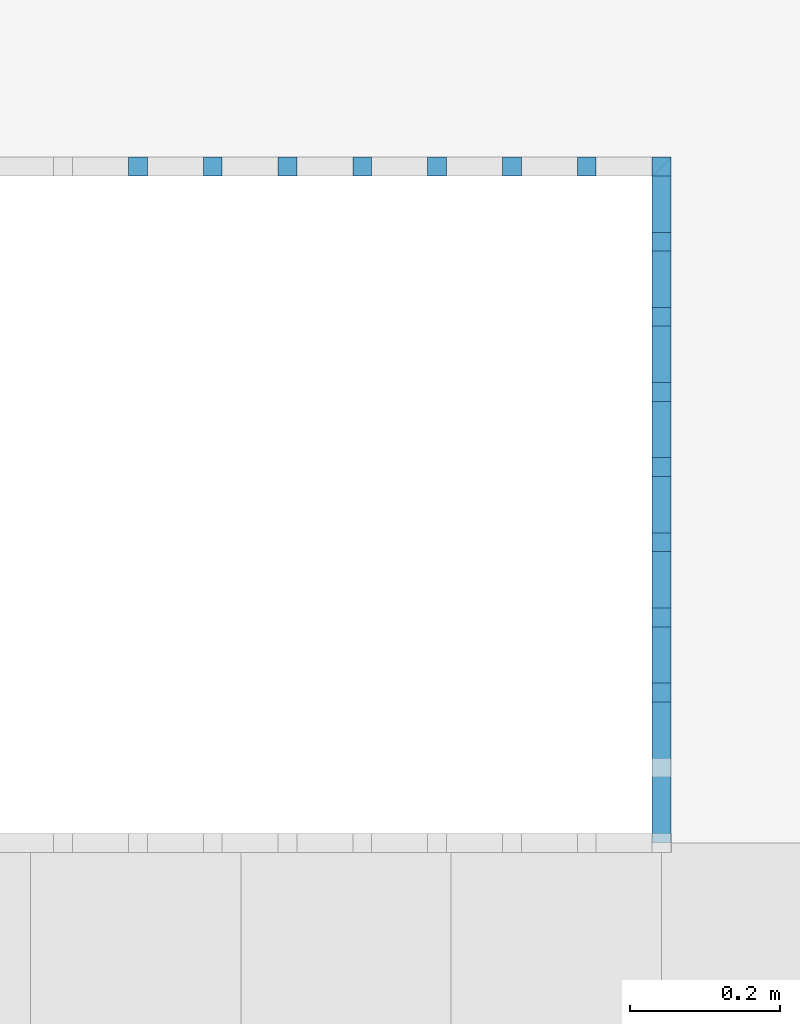
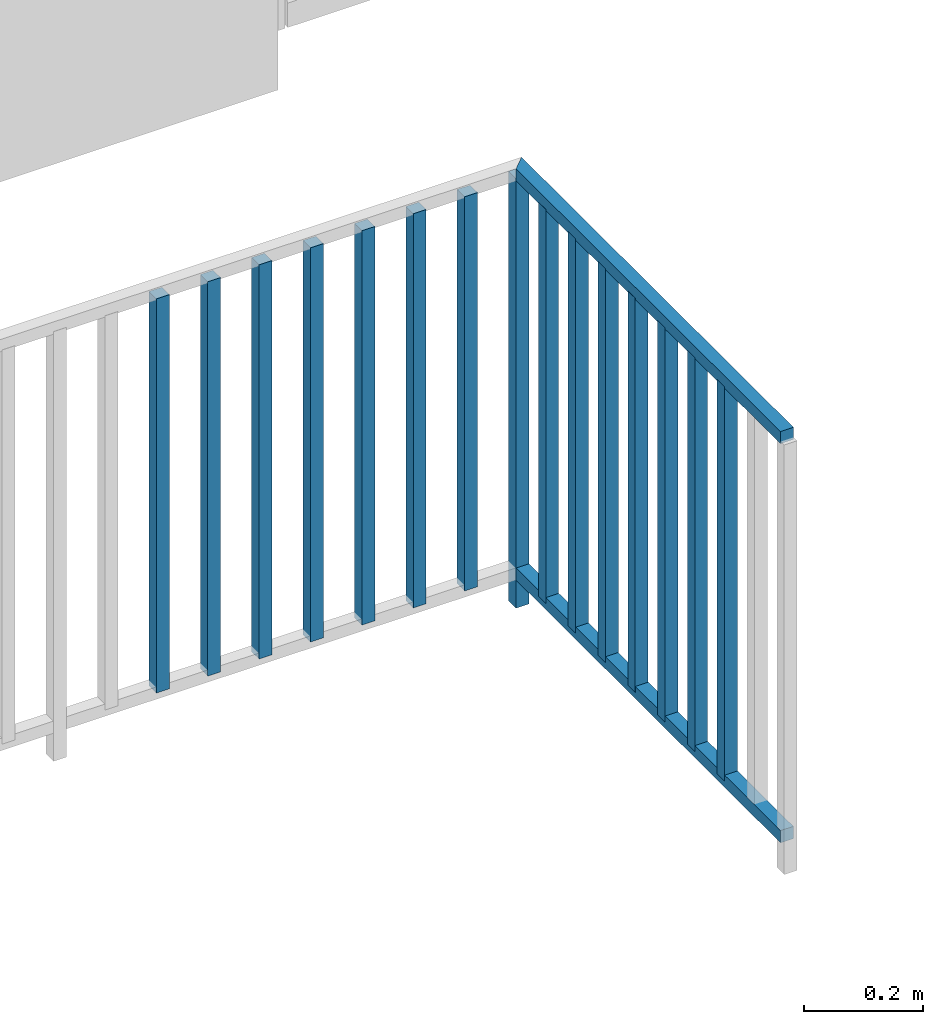
# One storey, part 35 of 48: 17 building element parts, 1 element without a shape of its own.
"""IFC4 building model written with IfcOpenShell, lengths in metres."""

from ifc_helpers import new_model, entity, si_unit, converted_unit, derived_unit, direction, frame, origin_with_axes, place, context, subcontext, project, spatial, polygons, material, type_object, element, aggregate, save


model = new_model("IFC4")

# Units and contexts
model_context = context("Model", 3, precision=1e-05, world=origin_with_axes(), true_north=direction((0.0, 1.0)))
body_context = subcontext(model_context, "Body", "Model", "MODEL_VIEW")
ifc_project = project(units=[si_unit("LENGTHUNIT", "METRE"), si_unit("AREAUNIT", "SQUARE_METRE"), si_unit("VOLUMEUNIT", "CUBIC_METRE"), converted_unit("PLANEANGLEUNIT", "DEGREE", entity("IfcPlaneAngleMeasure", 0.0174532925199), si_unit("PLANEANGLEUNIT", "RADIAN"), dimensions=[0, 0, 0, 0, 0, 0, 0]), converted_unit("TIMEUNIT", "Year", entity("IfcTimeMeasure", 31556926.0), si_unit("TIMEUNIT", "SECOND"), dimensions=[0, 0, 1, 0, 0, 0, 0]), si_unit("MASSUNIT", "GRAM", prefix="KILO"), si_unit("THERMODYNAMICTEMPERATUREUNIT", "DEGREE_CELSIUS"), si_unit("LUMINOUSINTENSITYUNIT", "LUMEN"), si_unit("ENERGYUNIT", "JOULE", prefix="MEGA"), derived_unit("THERMALCONDUCTANCEUNIT", [(si_unit("POWERUNIT", "WATT"), 1), (si_unit("LENGTHUNIT", "METRE"), -1), (si_unit("THERMODYNAMICTEMPERATUREUNIT", "KELVIN"), -1)]), derived_unit("SPECIFICHEATCAPACITYUNIT", [(si_unit("ENERGYUNIT", "JOULE"), 1), (si_unit("MASSUNIT", "GRAM", prefix="KILO"), -1), (si_unit("THERMODYNAMICTEMPERATUREUNIT", "KELVIN"), -1)]), derived_unit("MASSDENSITYUNIT", [(si_unit("MASSUNIT", "GRAM", prefix="KILO"), 1), (si_unit("VOLUMEUNIT", "CUBIC_METRE"), -1)])], contexts=[model_context])

# Site, building, storey, space
site_placement = place(None, origin_with_axes())
site = spatial("IfcSite", under=ifc_project, at=site_placement, CompositionType="ELEMENT")
building_placement = place(site_placement, origin_with_axes())
building = spatial("IfcBuilding", under=site, at=building_placement, CompositionType="ELEMENT")
storey_placement = place(building_placement, frame((0.0, 0.0, 3.4), z_axis=(0.0, 0.0, 1.0), x_axis=(1.0, 0.0, 0.0)))
storey = spatial("IfcBuildingStorey", under=building, at=storey_placement, Name="1. Geschoss", CompositionType="ELEMENT", Elevation=3.4)
space_placement = place(storey_placement, frame((-3.4421993804, -2.52881223104, 0.0), z_axis=(0.0, 0.0, 1.0), x_axis=(1.0, 0.0, 0.0)))
space = spatial("IfcSpace", under=storey, at=space_placement, CompositionType="ELEMENT", PredefinedType="INTERNAL")

# Railing, building element parts
railing_type = type_object("IfcRailingType", PredefinedType="NOTDEFINED")
railing_placement = place(space_placement, frame((0.0, 1.5, 0.0), z_axis=(0.0, 0.0, 1.0), x_axis=(1.0, 0.0, 0.0)))
railing = element("IfcRailing", 1, at=railing_placement, inside=space, type_object=railing_type, PredefinedType="NOTDEFINED")
ifc_material = material()
building_element_part_1_placement = place(railing_placement, origin_with_axes())
building_element_part_1 = element("IfcBuildingElementPart", 2, at=building_element_part_1_placement, material=ifc_material, PredefinedType="NOTDEFINED", context=body_context, shape_type="Tessellation", body=[
    polygons([(4.4925, 0.8875, 0.0), (4.4925, 0.9125, 0.0), (4.4925, 0.9125, 0.88), (4.4925, 0.8875, 0.88), (4.4675, 0.8875, 0.0), (4.4675, 0.9125, 0.0), (4.4675, 0.9125, 0.88), (4.4675, 0.8875, 0.88)], [[[1, 2, 3, 4]], [[1, 5, 6, 2]], [[2, 6, 7, 3]], [[4, 3, 7, 8]], [[5, 1, 4, 8]], [[6, 5, 8, 7]]], closed=True),
])
building_element_part_2_placement = place(railing_placement, origin_with_axes())
building_element_part_2 = element("IfcBuildingElementPart", 3, at=building_element_part_2_placement, material=ifc_material, PredefinedType="NOTDEFINED", context=body_context, shape_type="Tessellation", body=[
    polygons([(3.79561111111, 0.8875, 0.07), (3.79561111111, 0.9125, 0.07), (3.79561111111, 0.9125, 0.8775), (3.79561111111, 0.8875, 0.8775), (3.77061111111, 0.8875, 0.07), (3.77061111111, 0.9125, 0.07), (3.77061111111, 0.9125, 0.8775), (3.77061111111, 0.8875, 0.8775)], [[[1, 2, 3, 4]], [[1, 5, 6, 2]], [[2, 6, 7, 3]], [[4, 3, 7, 8]], [[5, 1, 4, 8]], [[6, 5, 8, 7]]], closed=True),
])
building_element_part_3_placement = place(railing_placement, origin_with_axes())
building_element_part_3 = element("IfcBuildingElementPart", 4, at=building_element_part_3_placement, material=ifc_material, PredefinedType="NOTDEFINED", context=body_context, shape_type="Tessellation", body=[
    polygons([(3.89516666667, 0.8875, 0.07), (3.89516666667, 0.9125, 0.07), (3.89516666667, 0.9125, 0.8775), (3.89516666667, 0.8875, 0.8775), (3.87016666667, 0.8875, 0.07), (3.87016666667, 0.9125, 0.07), (3.87016666667, 0.9125, 0.8775), (3.87016666667, 0.8875, 0.8775)], [[[1, 2, 3, 4]], [[1, 5, 6, 2]], [[2, 6, 7, 3]], [[4, 3, 7, 8]], [[5, 1, 4, 8]], [[6, 5, 8, 7]]], closed=True),
])
building_element_part_4_placement = place(railing_placement, origin_with_axes())
building_element_part_4 = element("IfcBuildingElementPart", 5, at=building_element_part_4_placement, material=ifc_material, PredefinedType="NOTDEFINED", context=body_context, shape_type="Tessellation", body=[
    polygons([(3.99472222222, 0.8875, 0.07), (3.99472222222, 0.9125, 0.07), (3.99472222222, 0.9125, 0.8775), (3.99472222222, 0.8875, 0.8775), (3.96972222222, 0.8875, 0.07), (3.96972222222, 0.9125, 0.07), (3.96972222222, 0.9125, 0.8775), (3.96972222222, 0.8875, 0.8775)], [[[1, 2, 3, 4]], [[1, 5, 6, 2]], [[2, 6, 7, 3]], [[4, 3, 7, 8]], [[5, 1, 4, 8]], [[6, 5, 8, 7]]], closed=True),
])
building_element_part_5_placement = place(railing_placement, origin_with_axes())
building_element_part_5 = element("IfcBuildingElementPart", 6, at=building_element_part_5_placement, material=ifc_material, PredefinedType="NOTDEFINED", context=body_context, shape_type="Tessellation", body=[
    polygons([(4.09427777778, 0.8875, 0.07), (4.09427777778, 0.9125, 0.07), (4.09427777778, 0.9125, 0.8775), (4.09427777778, 0.8875, 0.8775), (4.06927777778, 0.8875, 0.07), (4.06927777778, 0.9125, 0.07), (4.06927777778, 0.9125, 0.8775), (4.06927777778, 0.8875, 0.8775)], [[[1, 2, 3, 4]], [[1, 5, 6, 2]], [[2, 6, 7, 3]], [[4, 3, 7, 8]], [[5, 1, 4, 8]], [[6, 5, 8, 7]]], closed=True),
])
building_element_part_6_placement = place(railing_placement, origin_with_axes())
building_element_part_6 = element("IfcBuildingElementPart", 7, at=building_element_part_6_placement, material=ifc_material, PredefinedType="NOTDEFINED", context=body_context, shape_type="Tessellation", body=[
    polygons([(4.19383333333, 0.8875, 0.07), (4.19383333333, 0.9125, 0.07), (4.19383333333, 0.9125, 0.8775), (4.19383333333, 0.8875, 0.8775), (4.16883333333, 0.8875, 0.07), (4.16883333333, 0.9125, 0.07), (4.16883333333, 0.9125, 0.8775), (4.16883333333, 0.8875, 0.8775)], [[[1, 2, 3, 4]], [[1, 5, 6, 2]], [[2, 6, 7, 3]], [[4, 3, 7, 8]], [[5, 1, 4, 8]], [[6, 5, 8, 7]]], closed=True),
])
building_element_part_7_placement = place(railing_placement, origin_with_axes())
building_element_part_7 = element("IfcBuildingElementPart", 8, at=building_element_part_7_placement, material=ifc_material, PredefinedType="NOTDEFINED", context=body_context, shape_type="Tessellation", body=[
    polygons([(4.29338888889, 0.8875, 0.07), (4.29338888889, 0.9125, 0.07), (4.29338888889, 0.9125, 0.8775), (4.29338888889, 0.8875, 0.8775), (4.26838888889, 0.8875, 0.07), (4.26838888889, 0.9125, 0.07), (4.26838888889, 0.9125, 0.8775), (4.26838888889, 0.8875, 0.8775)], [[[1, 2, 3, 4]], [[1, 5, 6, 2]], [[2, 6, 7, 3]], [[4, 3, 7, 8]], [[5, 1, 4, 8]], [[6, 5, 8, 7]]], closed=True),
])
building_element_part_8_placement = place(railing_placement, origin_with_axes())
building_element_part_8 = element("IfcBuildingElementPart", 9, at=building_element_part_8_placement, material=ifc_material, PredefinedType="NOTDEFINED", context=body_context, shape_type="Tessellation", body=[
    polygons([(4.39294444444, 0.8875, 0.07), (4.39294444444, 0.9125, 0.07), (4.39294444444, 0.9125, 0.8775), (4.39294444444, 0.8875, 0.8775), (4.36794444444, 0.8875, 0.07), (4.36794444444, 0.9125, 0.07), (4.36794444444, 0.9125, 0.8775), (4.36794444444, 0.8875, 0.8775)], [[[1, 2, 3, 4]], [[1, 5, 6, 2]], [[2, 6, 7, 3]], [[4, 3, 7, 8]], [[5, 1, 4, 8]], [[6, 5, 8, 7]]], closed=True),
])
building_element_part_9_placement = place(railing_placement, origin_with_axes())
building_element_part_9 = element("IfcBuildingElementPart", 10, at=building_element_part_9_placement, material=ifc_material, PredefinedType="NOTDEFINED", context=body_context, shape_type="Tessellation", body=[
    polygons([(4.4675, 0.8875, 0.9), (4.4675, 0.8875, 0.875), (4.4675, 0.0, 0.875), (4.4675, 0.0, 0.9), (4.4925, 0.9125, 0.9), (4.4925, 0.9125, 0.875), (4.4925, 0.0, 0.875), (4.4925, 0.0, 0.9)], [[[1, 2, 3, 4]], [[1, 5, 6, 2]], [[2, 6, 7, 3]], [[4, 3, 7, 8]], [[5, 1, 4, 8]], [[6, 5, 8, 7]]], closed=True),
])
building_element_part_10_placement = place(railing_placement, origin_with_axes())
building_element_part_10 = element("IfcBuildingElementPart", 11, at=building_element_part_10_placement, material=ifc_material, PredefinedType="NOTDEFINED", context=body_context, shape_type="Tessellation", body=[
    polygons([(4.4675, 0.8875, 0.0825), (4.4675, 0.8875, 0.0575), (4.4675, 0.0, 0.0575), (4.4675, 0.0, 0.0825), (4.4925, 0.9125, 0.0825), (4.4925, 0.9125, 0.0575), (4.4925, 0.0, 0.0575), (4.4925, 0.0, 0.0825)], [[[1, 2, 3, 4]], [[1, 5, 6, 2]], [[2, 6, 7, 3]], [[4, 3, 7, 8]], [[5, 1, 4, 8]], [[6, 5, 8, 7]]], closed=True),
])
building_element_part_11_placement = place(railing_placement, origin_with_axes())
building_element_part_11 = element("IfcBuildingElementPart", 12, at=building_element_part_11_placement, material=ifc_material, PredefinedType="NOTDEFINED", context=body_context, shape_type="Tessellation", body=[
    polygons([(4.4675, 0.7875, 0.07), (4.4925, 0.7875, 0.07), (4.4925, 0.7875, 0.8775), (4.4675, 0.7875, 0.8775), (4.4675, 0.8125, 0.07), (4.4925, 0.8125, 0.07), (4.4925, 0.8125, 0.8775), (4.4675, 0.8125, 0.8775)], [[[1, 2, 3, 4]], [[1, 5, 6, 2]], [[2, 6, 7, 3]], [[4, 3, 7, 8]], [[5, 1, 4, 8]], [[6, 5, 8, 7]]], closed=True),
])
building_element_part_12_placement = place(railing_placement, origin_with_axes())
building_element_part_12 = element("IfcBuildingElementPart", 13, at=building_element_part_12_placement, material=ifc_material, PredefinedType="NOTDEFINED", context=body_context, shape_type="Tessellation", body=[
    polygons([(4.4675, 0.6875, 0.07), (4.4925, 0.6875, 0.07), (4.4925, 0.6875, 0.8775), (4.4675, 0.6875, 0.8775), (4.4675, 0.7125, 0.07), (4.4925, 0.7125, 0.07), (4.4925, 0.7125, 0.8775), (4.4675, 0.7125, 0.8775)], [[[1, 2, 3, 4]], [[1, 5, 6, 2]], [[2, 6, 7, 3]], [[4, 3, 7, 8]], [[5, 1, 4, 8]], [[6, 5, 8, 7]]], closed=True),
])
building_element_part_13_placement = place(railing_placement, origin_with_axes())
building_element_part_13 = element("IfcBuildingElementPart", 14, at=building_element_part_13_placement, material=ifc_material, PredefinedType="NOTDEFINED", context=body_context, shape_type="Tessellation", body=[
    polygons([(4.4675, 0.5875, 0.07), (4.4925, 0.5875, 0.07), (4.4925, 0.5875, 0.8775), (4.4675, 0.5875, 0.8775), (4.4675, 0.6125, 0.07), (4.4925, 0.6125, 0.07), (4.4925, 0.6125, 0.8775), (4.4675, 0.6125, 0.8775)], [[[1, 2, 3, 4]], [[1, 5, 6, 2]], [[2, 6, 7, 3]], [[4, 3, 7, 8]], [[5, 1, 4, 8]], [[6, 5, 8, 7]]], closed=True),
])
building_element_part_14_placement = place(railing_placement, origin_with_axes())
building_element_part_14 = element("IfcBuildingElementPart", 15, at=building_element_part_14_placement, material=ifc_material, PredefinedType="NOTDEFINED", context=body_context, shape_type="Tessellation", body=[
    polygons([(4.4675, 0.4875, 0.07), (4.4925, 0.4875, 0.07), (4.4925, 0.4875, 0.8775), (4.4675, 0.4875, 0.8775), (4.4675, 0.5125, 0.07), (4.4925, 0.5125, 0.07), (4.4925, 0.5125, 0.8775), (4.4675, 0.5125, 0.8775)], [[[1, 2, 3, 4]], [[1, 5, 6, 2]], [[2, 6, 7, 3]], [[4, 3, 7, 8]], [[5, 1, 4, 8]], [[6, 5, 8, 7]]], closed=True),
])
building_element_part_15_placement = place(railing_placement, origin_with_axes())
building_element_part_15 = element("IfcBuildingElementPart", 16, at=building_element_part_15_placement, material=ifc_material, PredefinedType="NOTDEFINED", context=body_context, shape_type="Tessellation", body=[
    polygons([(4.4675, 0.3875, 0.07), (4.4925, 0.3875, 0.07), (4.4925, 0.3875, 0.8775), (4.4675, 0.3875, 0.8775), (4.4675, 0.4125, 0.07), (4.4925, 0.4125, 0.07), (4.4925, 0.4125, 0.8775), (4.4675, 0.4125, 0.8775)], [[[1, 2, 3, 4]], [[1, 5, 6, 2]], [[2, 6, 7, 3]], [[4, 3, 7, 8]], [[5, 1, 4, 8]], [[6, 5, 8, 7]]], closed=True),
])
building_element_part_16_placement = place(railing_placement, origin_with_axes())
building_element_part_16 = element("IfcBuildingElementPart", 17, at=building_element_part_16_placement, material=ifc_material, PredefinedType="NOTDEFINED", context=body_context, shape_type="Tessellation", body=[
    polygons([(4.4675, 0.2875, 0.07), (4.4925, 0.2875, 0.07), (4.4925, 0.2875, 0.8775), (4.4675, 0.2875, 0.8775), (4.4675, 0.3125, 0.07), (4.4925, 0.3125, 0.07), (4.4925, 0.3125, 0.8775), (4.4675, 0.3125, 0.8775)], [[[1, 2, 3, 4]], [[1, 5, 6, 2]], [[2, 6, 7, 3]], [[4, 3, 7, 8]], [[5, 1, 4, 8]], [[6, 5, 8, 7]]], closed=True),
])
building_element_part_17_placement = place(railing_placement, origin_with_axes())
building_element_part_17 = element("IfcBuildingElementPart", 18, at=building_element_part_17_placement, material=ifc_material, PredefinedType="NOTDEFINED", context=body_context, shape_type="Tessellation", body=[
    polygons([(4.4675, 0.1875, 0.07), (4.4925, 0.1875, 0.07), (4.4925, 0.1875, 0.8775), (4.4675, 0.1875, 0.8775), (4.4675, 0.2125, 0.07), (4.4925, 0.2125, 0.07), (4.4925, 0.2125, 0.8775), (4.4675, 0.2125, 0.8775)], [[[1, 2, 3, 4]], [[1, 5, 6, 2]], [[2, 6, 7, 3]], [[4, 3, 7, 8]], [[5, 1, 4, 8]], [[6, 5, 8, 7]]], closed=True),
])
aggregate(railing, [building_element_part_1, building_element_part_2, building_element_part_3, building_element_part_4, building_element_part_5, building_element_part_6, building_element_part_7, building_element_part_8, building_element_part_9, building_element_part_10, building_element_part_11, building_element_part_12, building_element_part_13, building_element_part_14, building_element_part_15, building_element_part_16, building_element_part_17])

save(model, "model.ifc")
